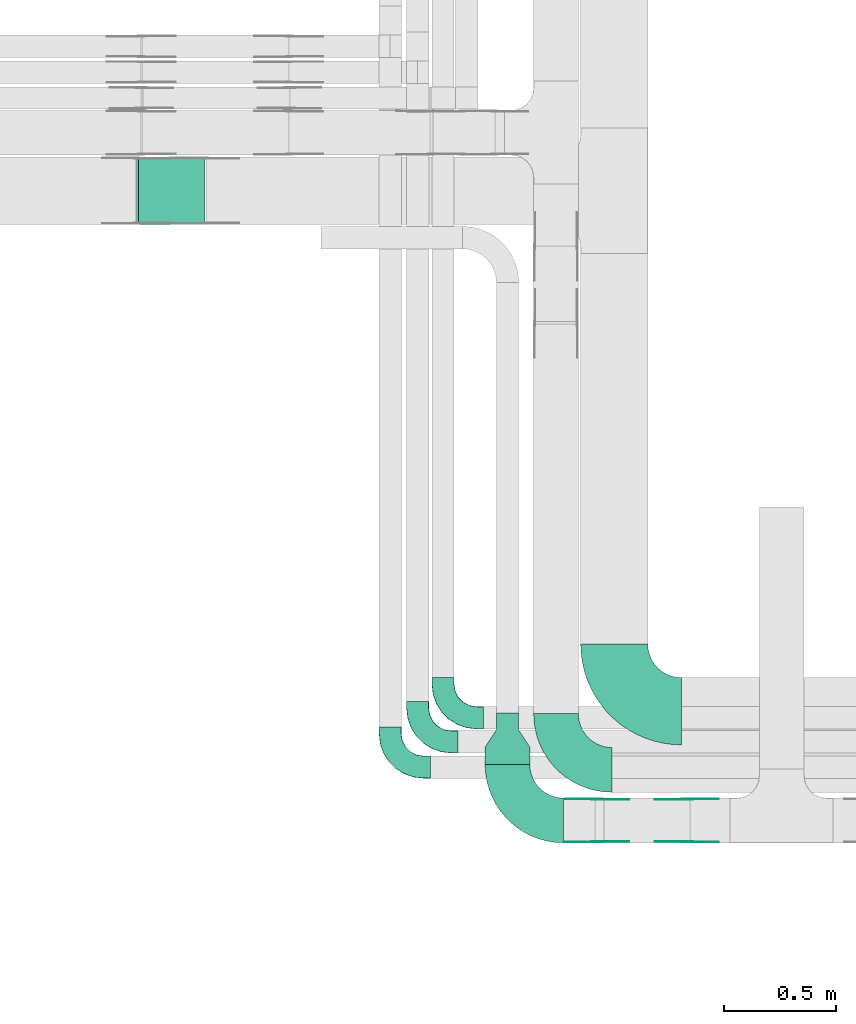
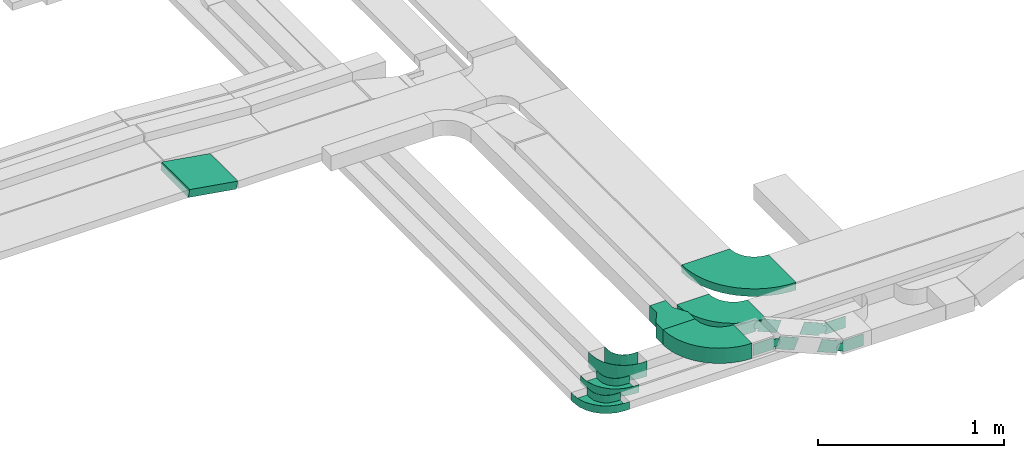
# One storey, part 3 of 19: 15 flow fittings, 1 flow segment.
"""IFC2X3 building model written with IfcOpenShell, lengths in millimetres."""

from ifc_helpers import new_model, entity, si_unit, converted_unit, derived_unit, direction, frame, frame_2d, origin, origin_2d_with_axis, place, context, subcontext, project, spatial, polyline, circle_curve, parameter, trimmed, segment, composite_curve, rectangle, outline, extrude, faceted_brep, source, transform, mapped, material, type_object, type_shapes, element, save


model = new_model("IFC2X3")

# Units and contexts
model_context = context("Model", 3, precision=0.01, world=origin(), true_north=direction((6.12303176911189e-17, 1.0)))
body_context = subcontext(model_context, "Body", "Model", "MODEL_VIEW")
ifc_project = project(units=[si_unit("LENGTHUNIT", "METRE", prefix="MILLI"), si_unit("AREAUNIT", "SQUARE_METRE"), si_unit("VOLUMEUNIT", "CUBIC_METRE"), converted_unit("PLANEANGLEUNIT", "DEGREE", entity("IfcRatioMeasure", 0.0174532925199433), si_unit("PLANEANGLEUNIT", "RADIAN"), dimensions=[0, 0, 0, 0, 0, 0, 0]), si_unit("MASSUNIT", "GRAM", prefix="KILO"), derived_unit("MASSDENSITYUNIT", [(si_unit("MASSUNIT", "GRAM", prefix="KILO"), 1), (si_unit("LENGTHUNIT", "METRE"), -3)]), derived_unit("MOMENTOFINERTIAUNIT", [(si_unit("LENGTHUNIT", "METRE"), 4)]), si_unit("TIMEUNIT", "SECOND"), si_unit("FREQUENCYUNIT", "HERTZ"), si_unit("THERMODYNAMICTEMPERATUREUNIT", "DEGREE_CELSIUS"), derived_unit("THERMALTRANSMITTANCEUNIT", [(si_unit("MASSUNIT", "GRAM", prefix="KILO"), 1), (si_unit("THERMODYNAMICTEMPERATUREUNIT", "KELVIN"), -1), (si_unit("TIMEUNIT", "SECOND"), -3)]), derived_unit("VOLUMETRICFLOWRATEUNIT", [(si_unit("LENGTHUNIT", "METRE"), 3), (si_unit("TIMEUNIT", "SECOND"), -1)]), derived_unit("MASSFLOWRATEUNIT", [(si_unit("MASSUNIT", "GRAM", prefix="KILO"), 1), (si_unit("TIMEUNIT", "SECOND"), -1)]), derived_unit("ROTATIONALFREQUENCYUNIT", [(si_unit("TIMEUNIT", "SECOND"), -1)]), si_unit("ELECTRICCURRENTUNIT", "AMPERE"), si_unit("ELECTRICVOLTAGEUNIT", "VOLT"), si_unit("POWERUNIT", "WATT"), si_unit("FORCEUNIT", "NEWTON", prefix="KILO"), si_unit("ILLUMINANCEUNIT", "LUX"), si_unit("LUMINOUSFLUXUNIT", "LUMEN"), si_unit("LUMINOUSINTENSITYUNIT", "CANDELA"), derived_unit("USERDEFINED", [(si_unit("MASSUNIT", "GRAM", prefix="KILO"), -1), (si_unit("LENGTHUNIT", "METRE"), -2), (si_unit("TIMEUNIT", "SECOND"), 3), (si_unit("LUMINOUSFLUXUNIT", "LUMEN"), 1)]), derived_unit("LINEARVELOCITYUNIT", [(si_unit("LENGTHUNIT", "METRE"), 1), (si_unit("TIMEUNIT", "SECOND"), -1)]), si_unit("PRESSUREUNIT", "PASCAL"), derived_unit("USERDEFINED", [(si_unit("LENGTHUNIT", "METRE"), -2), (si_unit("MASSUNIT", "GRAM", prefix="KILO"), 1), (si_unit("TIMEUNIT", "SECOND"), -2)]), derived_unit("LINEARFORCEUNIT", [(si_unit("MASSUNIT", "GRAM", prefix="KILO"), 1), (si_unit("LENGTHUNIT", "METRE"), 1), (si_unit("TIMEUNIT", "SECOND"), -2), (si_unit("LENGTHUNIT", "METRE"), -1)]), derived_unit("PLANARFORCEUNIT", [(si_unit("MASSUNIT", "GRAM", prefix="KILO"), 1), (si_unit("LENGTHUNIT", "METRE"), 1), (si_unit("TIMEUNIT", "SECOND"), -2), (si_unit("LENGTHUNIT", "METRE"), -2)])], contexts=[model_context])

# Site, building, storey
site_placement = place(None, frame((0.0, -0.00077364408347762, 0.0)))
site = spatial("IfcSite", under=ifc_project, at=site_placement, CompositionType="ELEMENT")
building_placement = place(site_placement, origin())
building = spatial("IfcBuilding", under=site, at=building_placement, CompositionType="ELEMENT")
storey_placement = place(building_placement, frame((0.0, 0.0, 12000.0)))
storey = spatial("IfcBuildingStorey", under=building, at=storey_placement, CompositionType="ELEMENT", Elevation=12000.0)

# Flow segment
cable_carrier_segment_type = type_object("IfcCableCarrierSegmentType", PredefinedType="CABLETRAYSEGMENT")
flow_segment_placement = place(storey_placement, frame((16244.9623547162, 12249.7910307987, 2800.87178897478)))
element("IfcFlowSegment", 1, at=flow_segment_placement, inside=storey, type_object=cable_carrier_segment_type, context=body_context, shape_type="SweptSolid", body=[
    extrude(rectangle(XDim=50.0000000000021, YDim=300.000000000001, at=origin_2d_with_axis()), frame((4.04109573358495, 150.0, 73.5851929511431), z_axis=(0.986849163973504, 0.0, -0.161643829343391), x_axis=(0.161643829343391, 0.0, 0.986849163973504)), (0.0, 0.0, 1.0), 302.603347436749),
])

# Flow fittings
ifc_material_1 = material()
cable_carrier_fitting_type_1 = type_object("IfcCableCarrierFittingType", Name="470_DKC_S5_Variable Angle Elbow 0-45:-", PredefinedType="NOTDEFINED", material=ifc_material_1)
shared_shape_1 = source(origin(), body_context, "Body", "SweptSolid", [
    extrude(outline(composite_curve([segment(polyline([(-150.749999999996, -300.250000000003), (-149.749999999994, -300.250000000003)]), True, "CONTINUOUS"), segment(trimmed(circle_curve(frame_2d((-149.750000000002, 149.749999999997), x_axis=(0.0, -1.0)), 450.0), [parameter(0.0)], [parameter(90.0000000000001)], True, "PARAMETER"), True, "CONTINUOUS"), segment(polyline([(300.249999999997, 149.750000000005), (300.249999999997, 150.750000000004)]), True, "CONTINUOUS"), segment(polyline([(300.249999999997, 150.750000000003), (0.249999999997449, 150.750000000002)]), True, "CONTINUOUS"), segment(polyline([(0.249999999997449, 150.750000000002), (0.249999999997438, 149.75)]), True, "CONTINUOUS"), segment(trimmed(circle_curve(frame_2d((-149.750000000002, 149.749999999997), x_axis=(0.0, -1.0)), 150.0), [parameter(0.0)], [parameter(90.0000000000001)], True, "PARAMETER"), False, "CONTINUOUS"), segment(polyline([(-149.749999999999, -0.250000000002818), (-150.750000000001, -0.250000000002835)]), True, "CONTINUOUS"), segment(polyline([(-150.750000000001, -0.250000000002835), (-150.749999999996, -300.250000000003)]), True, "CONTINUOUS")], self_intersect=False)), frame((-150.249999999991, 150.249999999992, -25.0)), (0.0, 0.0, 1.0), 49.9999999999974),
])
type_shapes(cable_carrier_fitting_type_1, [shared_shape_1])
flow_fitting_1_placement = place(storey_placement, frame((18378.5368087494, 10074.9424515466, 2825.0), z_axis=(0.0, 0.0, 1.0), x_axis=(0.0, -1.0, 0.0)))
element("IfcFlowFitting", 2, at=flow_fitting_1_placement, inside=storey, type_object=cable_carrier_fitting_type_1, material=ifc_material_1, Name="470_DKC_S5_Variable Angle Elbow 0-45:-", ObjectType="470_DKC_S5_Variable Angle Elbow 0-45:-", context=body_context, shape_type="MappedRepresentation", body=[
    mapped(shared_shape_1, transform((0.0, 0.0, 0.0), scale=1.0)),
])
cable_carrier_fitting_type_2 = type_object("IfcCableCarrierFittingType", Name="470_DKC_S5_Variable Angle Elbow 0-45:-", PredefinedType="NOTDEFINED", material=ifc_material_1)
shared_shape_2 = source(origin(), body_context, "Body", "SweptSolid", [
    extrude(outline(composite_curve([segment(polyline([(-125.750000000004, -225.249999999998), (-124.750000000003, -225.249999999998)]), True, "CONTINUOUS"), segment(trimmed(circle_curve(frame_2d((-124.749999999998, 124.750000000002), x_axis=(0.0, -1.0)), 350.0), [parameter(0.0)], [parameter(90.0000000000001)], True, "PARAMETER"), True, "CONTINUOUS"), segment(polyline([(225.250000000002, 124.749999999996), (225.250000000002, 125.749999999995)]), True, "CONTINUOUS"), segment(polyline([(225.250000000002, 125.749999999995), (25.2500000000021, 125.750000000001)]), True, "CONTINUOUS"), segment(polyline([(25.2500000000021, 125.750000000001), (25.2500000000021, 124.749999999999)]), True, "CONTINUOUS"), segment(trimmed(circle_curve(frame_2d((-124.749999999998, 124.750000000002), x_axis=(0.0, -1.0)), 150.0), [parameter(0.0)], [parameter(90.0000000000001)], True, "PARAMETER"), False, "CONTINUOUS"), segment(polyline([(-124.75, -25.2499999999982), (-125.750000000001, -25.2499999999981)]), True, "CONTINUOUS"), segment(polyline([(-125.750000000001, -25.2499999999981), (-125.750000000004, -225.249999999998)]), True, "CONTINUOUS")], self_intersect=False)), frame((-125.249999999991, 125.249999999992, -25.0)), (0.0, 0.0, 1.0), 50.000000000001),
])
type_shapes(cable_carrier_fitting_type_2, [shared_shape_2])
flow_fitting_2_placement = place(storey_placement, frame((18118.5874268759, 9813.17561885424, 2825.80524984479), z_axis=(0.0, 0.0, 1.0), x_axis=(0.0, -1.0, 0.0)))
element("IfcFlowFitting", 3, at=flow_fitting_2_placement, inside=storey, type_object=cable_carrier_fitting_type_2, material=ifc_material_1, Name="470_DKC_S5_Variable Angle Elbow 0-45:-", ObjectType="470_DKC_S5_Variable Angle Elbow 0-45:-", context=body_context, shape_type="MappedRepresentation", body=[
    mapped(shared_shape_2, transform((0.0, 0.0, 0.0), scale=1.0)),
])
ifc_material_2 = material(Name="G")
cable_carrier_fitting_type_3 = type_object("IfcCableCarrierFittingType", PredefinedType="NOTDEFINED", material=ifc_material_2)
shared_shape_3 = source(origin(), body_context, "Body", "SweptSolid", [
    extrude(outline(composite_curve([segment(trimmed(circle_curve(frame_2d((-41.4651162790697, 0.0), x_axis=(1.0, 0.0)), 25.0), [parameter(90.0000000000007)], [parameter(270.0)], True, "PARAMETER"), True, "CONTINUOUS"), segment(polyline([(-41.4651162790697, -25.0), (-29.9651162790697, -25.0)]), True, "CONTINUOUS"), segment(polyline([(-29.9651162790697, -25.0), (-28.1046511627907, -38.5)]), True, "CONTINUOUS"), segment(polyline([(-28.1046511627907, -38.5), (99.5348837209303, -38.5)]), True, "CONTINUOUS"), segment(polyline([(99.5348837209303, -38.5), (99.5348837209303, 38.5)]), True, "CONTINUOUS"), segment(polyline([(99.5348837209303, 38.5), (-28.1046511627907, 38.5)]), True, "CONTINUOUS"), segment(polyline([(-28.1046511627907, 38.5), (-29.9651162790697, 25.0)]), True, "CONTINUOUS"), segment(polyline([(-29.9651162790697, 25.0), (-41.46511627907, 25.0)]), True, "CONTINUOUS")], self_intersect=False)), frame((41.4651162790697, 0.0, 0.0), z_axis=(0.0, 0.0, -1.0), x_axis=(1.0, 0.0, 0.0)), (0.0, 0.0, -1.0), 2.0),
])
type_shapes(cable_carrier_fitting_type_3, [shared_shape_3])
for number, where, z_axis, x_axis in (
    (4, (18301.6734101346, 9491.98715306406, 2850.0), (0.0, -1.0, 0.0), (-1.0, 0.0, 0.0)),
    (5, (18705.34797877, 9491.98715306406, 2678.65031167224), (0.0, -1.0, 0.0), (1.0, 0.0, 0.0)),
):
    element("IfcFlowFitting", number, at=place(storey_placement, frame(where, z_axis=z_axis, x_axis=x_axis)), inside=storey, type_object=cable_carrier_fitting_type_3, material=ifc_material_2, context=body_context, shape_type="MappedRepresentation", body=[
        mapped(shared_shape_3, transform((0.0, 0.0, 0.0), scale=1.0)),
    ])
cable_carrier_fitting_type_4 = type_object("IfcCableCarrierFittingType", PredefinedType="NOTDEFINED", material=ifc_material_2)
shared_shape_4 = source(origin(), body_context, "Body", "SweptSolid", [
    extrude(outline(composite_curve([segment(trimmed(circle_curve(frame_2d((-41.4651162790697, 0.0), x_axis=(1.0, 0.0)), 25.0), [parameter(90.0000000000007)], [parameter(270.0)], True, "PARAMETER"), True, "CONTINUOUS"), segment(polyline([(-41.4651162790697, -25.0), (-29.9651162790697, -25.0)]), True, "CONTINUOUS"), segment(polyline([(-29.9651162790697, -25.0), (-28.1046511627907, -38.5)]), True, "CONTINUOUS"), segment(polyline([(-28.1046511627907, -38.5), (99.5348837209303, -38.5)]), True, "CONTINUOUS"), segment(polyline([(99.5348837209303, -38.5), (99.5348837209303, 38.5)]), True, "CONTINUOUS"), segment(polyline([(99.5348837209303, 38.5), (-28.1046511627907, 38.5)]), True, "CONTINUOUS"), segment(polyline([(-28.1046511627907, 38.5), (-29.9651162790697, 25.0)]), True, "CONTINUOUS"), segment(polyline([(-29.9651162790697, 25.0), (-41.46511627907, 25.0)]), True, "CONTINUOUS")], self_intersect=False)), frame((41.4651162790697, 0.0, 0.0)), (0.0, 0.0, 1.0), 2.0),
])
type_shapes(cable_carrier_fitting_type_4, [shared_shape_4])
for number, where, z_axis, x_axis in (
    (6, (18301.6734101346, 9682.90715308437, 2850.0), (0.0, 1.0, 0.0), (-1.0, 0.0, 0.0)),
    (7, (18705.34797877, 9682.90715308437, 2678.65031167224), (0.0, 1.0, 0.0), (1.0, 0.0, 0.0)),
):
    element("IfcFlowFitting", number, at=place(storey_placement, frame(where, z_axis=z_axis, x_axis=x_axis)), inside=storey, type_object=cable_carrier_fitting_type_4, material=ifc_material_2, context=body_context, shape_type="MappedRepresentation", body=[
        mapped(shared_shape_4, transform((0.0, 0.0, 0.0), scale=1.0)),
    ])
cable_carrier_fitting_type_5 = type_object("IfcCableCarrierFittingType", PredefinedType="NOTDEFINED", material=ifc_material_2)
shared_shape_5 = source(origin(), body_context, "Body", "SweptSolid", [
    extrude(outline(composite_curve([segment(trimmed(circle_curve(frame_2d((-41.4651162790697, 0.0), x_axis=(1.0, 0.0)), 25.0), [parameter(90.0000000000007)], [parameter(270.0)], True, "PARAMETER"), True, "CONTINUOUS"), segment(polyline([(-41.4651162790697, -25.0), (-29.9651162790697, -25.0)]), True, "CONTINUOUS"), segment(polyline([(-29.9651162790697, -25.0), (-28.1046511627907, -38.5)]), True, "CONTINUOUS"), segment(polyline([(-28.1046511627907, -38.5), (99.5348837209303, -38.5)]), True, "CONTINUOUS"), segment(polyline([(99.5348837209303, -38.5), (99.5348837209303, 38.5)]), True, "CONTINUOUS"), segment(polyline([(99.5348837209303, 38.5), (-28.1046511627907, 38.5)]), True, "CONTINUOUS"), segment(polyline([(-28.1046511627907, 38.5), (-29.9651162790697, 25.0)]), True, "CONTINUOUS"), segment(polyline([(-29.9651162790697, 25.0), (-41.46511627907, 25.0)]), True, "CONTINUOUS")], self_intersect=False)), frame((41.4651162790697, 0.0, 0.0), z_axis=(0.0, 0.0, -1.0), x_axis=(1.0, 0.0, 0.0)), (0.0, 0.0, -1.0), 2.0),
])
type_shapes(cable_carrier_fitting_type_5, [shared_shape_5])
for number, where, z_axis, x_axis in (
    (8, (18301.6734101346, 9680.90715308437, 2850.0), (0.0, 1.0, 0.0), (0.920504853452409, 0.0, -0.390731128489347)),
    (9, (18705.3479787701, 9680.90715308437, 2678.65031167224), (0.0, 1.0, 0.0), (-0.920504853454354, 0.0, 0.390731128484765)),
):
    element("IfcFlowFitting", number, at=place(storey_placement, frame(where, z_axis=z_axis, x_axis=x_axis)), inside=storey, type_object=cable_carrier_fitting_type_5, material=ifc_material_2, context=body_context, shape_type="MappedRepresentation", body=[
        mapped(shared_shape_5, transform((0.0, 0.0, 0.0), scale=1.0)),
    ])
cable_carrier_fitting_type_6 = type_object("IfcCableCarrierFittingType", PredefinedType="NOTDEFINED", material=ifc_material_2)
shared_shape_6 = source(origin(), body_context, "Body", "SweptSolid", [
    extrude(outline(composite_curve([segment(trimmed(circle_curve(frame_2d((-41.4651162790697, 0.0), x_axis=(1.0, 0.0)), 25.0), [parameter(90.0000000000007)], [parameter(270.0)], True, "PARAMETER"), True, "CONTINUOUS"), segment(polyline([(-41.4651162790697, -25.0), (-29.9651162790697, -25.0)]), True, "CONTINUOUS"), segment(polyline([(-29.9651162790697, -25.0), (-28.1046511627907, -38.5)]), True, "CONTINUOUS"), segment(polyline([(-28.1046511627907, -38.5), (99.5348837209303, -38.5)]), True, "CONTINUOUS"), segment(polyline([(99.5348837209303, -38.5), (99.5348837209303, 38.5)]), True, "CONTINUOUS"), segment(polyline([(99.5348837209303, 38.5), (-28.1046511627907, 38.5)]), True, "CONTINUOUS"), segment(polyline([(-28.1046511627907, 38.5), (-29.9651162790697, 25.0)]), True, "CONTINUOUS"), segment(polyline([(-29.9651162790697, 25.0), (-41.46511627907, 25.0)]), True, "CONTINUOUS")], self_intersect=False)), frame((41.4651162790697, 0.0, 0.0)), (0.0, 0.0, 1.0), 2.0),
])
type_shapes(cable_carrier_fitting_type_6, [shared_shape_6])
for number, where, z_axis, x_axis in (
    (10, (18301.6734101346, 9493.98715306406, 2850.0), (0.0, -1.0, 0.0), (0.920504853452409, 0.0, -0.390731128489347)),
    (11, (18705.3479787701, 9493.98715306406, 2678.65031167224), (0.0, -1.0, 0.0), (-0.920504853454354, 0.0, 0.390731128484765)),
):
    element("IfcFlowFitting", number, at=place(storey_placement, frame(where, z_axis=z_axis, x_axis=x_axis)), inside=storey, type_object=cable_carrier_fitting_type_6, material=ifc_material_2, context=body_context, shape_type="MappedRepresentation", body=[
        mapped(shared_shape_6, transform((0.0, 0.0, 0.0), scale=1.0)),
    ])
cable_carrier_fitting_type_7 = type_object("IfcCableCarrierFittingType", Name="470_DKC_S5_Variable Angle Elbow 0-45:-", PredefinedType="NOTDEFINED", material=ifc_material_1)
shared_shape_7 = source(origin(), body_context, "Body", "SweptSolid", [
    extrude(outline(composite_curve([segment(polyline([(-125.750000000001, -225.25), (-124.749999999999, -225.25)]), True, "CONTINUOUS"), segment(trimmed(circle_curve(frame_2d((-124.75, 124.75), x_axis=(0.0, -1.0)), 350.0), [parameter(0.0)], [parameter(90.0000000000001)], True, "PARAMETER"), True, "CONTINUOUS"), segment(polyline([(225.25, 124.75), (225.25, 125.749999999999)]), True, "CONTINUOUS"), segment(polyline([(225.25, 125.749999999999), (25.25, 125.750000000001)]), True, "CONTINUOUS"), segment(polyline([(25.25, 125.750000000001), (25.25, 124.75)]), True, "CONTINUOUS"), segment(trimmed(circle_curve(frame_2d((-124.75, 124.75), x_axis=(0.0, -1.0)), 150.0), [parameter(0.0)], [parameter(90.0000000000001)], True, "PARAMETER"), False, "CONTINUOUS"), segment(polyline([(-124.749999999999, -25.2500000000003), (-125.750000000001, -25.2500000000003)]), True, "CONTINUOUS"), segment(polyline([(-125.750000000001, -25.2500000000003), (-125.750000000001, -225.25)]), True, "CONTINUOUS")], self_intersect=False)), frame((-125.249999999991, 125.249999999992, -50.0)), (0.0, 0.0, 1.0), 100.0),
])
type_shapes(cable_carrier_fitting_type_7, [shared_shape_7])
flow_fitting_3_placement = place(storey_placement, frame((17901.6734101346, 9587.44715307423, 2850.0), z_axis=(0.0, 0.0, 1.0), x_axis=(0.0, -1.0, 0.0)))
element("IfcFlowFitting", 12, at=flow_fitting_3_placement, inside=storey, type_object=cable_carrier_fitting_type_7, material=ifc_material_1, Name="470_DKC_S5_Variable Angle Elbow 0-45:-", ObjectType="470_DKC_S5_Variable Angle Elbow 0-45:-", context=body_context, shape_type="MappedRepresentation", body=[
    mapped(shared_shape_7, transform((0.0, 0.0, 0.0), scale=1.0)),
])
cable_carrier_fitting_type_8 = type_object("IfcCableCarrierFittingType", PredefinedType="NOTDEFINED", material=ifc_material_1)
shared_shape_8 = source(origin(), body_context, "Body", "SweptSolid", [
    extrude(outline(polyline([(-115.0, -100.0), (-38.3333333333284, -100.0), (38.3333333333252, -50.0), (115.0, -50.0), (115.0, 50.0), (38.3333333333382, 50.0), (-38.3333333333284, 100.0), (-115.0, 100.0), (-115.0, -100.0)])), frame((115.0, 0.0, -50.0)), (0.0, 0.0, 1.0), 100.0),
])
type_shapes(cable_carrier_fitting_type_8, [shared_shape_8])
flow_fitting_4_placement = place(storey_placement, frame((17901.6734101346, 9838.44715307421, 2850.0), z_axis=(0.0, 0.0, 1.0), x_axis=(0.0, 1.0, 0.0)))
element("IfcFlowFitting", 13, at=flow_fitting_4_placement, inside=storey, type_object=cable_carrier_fitting_type_8, material=ifc_material_1, Name="470_DKC_S5_adapter", context=body_context, shape_type="MappedRepresentation", body=[
    mapped(shared_shape_8, transform((0.0, 0.0, 0.0), scale=1.0)),
])
cable_carrier_fitting_type_9 = type_object("IfcCableCarrierFittingType", Name="470_DKC_S5_CPO 45 horizontal angle:-", PredefinedType="NOTDEFINED", material=ifc_material_1)
shared_shape_9 = source(origin(), body_context, "Body", "Brep", [
    faceted_brep([(-180.0, -49.2000000000082, -49.2000000000019), (-180.0, 49.1999999999917, -49.2000000000019), (-180.0, 49.1999999999917, 50.0), (-180.0, 50.0, 50.0), (-180.0, 50.0, -50.0), (-180.0, -50.0, -50.0), (-180.0, -50.0, 50.0), (-180.0, -49.2000000000082, 50.0), (-150.0, -50.0, -50.0), (-150.0, -50.0, 50.0), (-105.495813208728, -44.9855824363732, 50.0), (-63.2232521764796, -30.1937735804923, 50.0), (-25.3020396282445, -6.36629649361443, 50.0), (6.3662964936147, 25.3020396282448, 50.0), (30.1937735804926, 63.2232521764798, 50.0), (44.9855824363735, 105.495813208729, 50.0), (50.0, 150.0, 50.0), (50.0, 180.0, 50.0), (49.2000000000087, 180.0, 50.0), (49.2000000000086, 150.0, 50.0), (44.2056401066279, 105.673829955894, 50.0), (29.4729984861705, 63.5703591677739, 50.0), (5.74083130764015, 25.8008314697319, 50.0), (-25.8008314697316, -5.74083130763988, 50.0), (-63.5703591677737, -29.4729984861702, 50.0), (-105.673829955893, -44.2056401066275, 50.0), (-150.0, -49.2000000000082, 50.0), (-150.0, 49.1999999999917, 50.0), (-118.851086966997, 54.1335031574402, 50.0), (-90.75124656891, 68.451086966997, 50.0), (-68.4510869669966, 90.7512465689103, 50.0), (-54.1335031574399, 118.851086966997, 50.0), (-49.1999999999913, 150.0, 50.0), (-49.1999999999912, 180.0, 50.0), (-50.0, 180.0, 50.0), (-50.0, 150.0, 50.0), (-54.8943483704758, 119.098300562497, 50.0), (-69.0983005624964, 91.2214747707442, 50.0), (-91.2214747707439, 69.0983005624968, 50.0), (-119.098300562496, 54.8943483704762, 50.0), (-150.0, 50.0, 50.0), (-150.0, -49.2000000000082, -49.2000000000019), (-105.673829955893, -44.2056401066275, -49.2000000000019), (-63.5703591677737, -29.4729984861702, -49.2000000000019), (-25.8008314697316, -5.74083130763988, -49.2000000000019), (5.74083130764015, 25.8008314697319, -49.2000000000019), (29.4729984861705, 63.5703591677739, -49.2000000000019), (44.2056401066279, 105.673829955894, -49.2000000000019), (49.2000000000087, 150.0, -49.2000000000019), (49.2000000000087, 180.0, -49.2000000000019), (-49.1999999999912, 180.0, -49.2000000000019), (-49.1999999999913, 150.0, -49.2000000000019), (-54.1335031574399, 118.851086966997, -49.2000000000019), (-68.4510869669966, 90.7512465689103, -49.2000000000019), (-90.75124656891, 68.451086966997, -49.2000000000019), (-118.851086966997, 54.1335031574402, -49.2000000000019), (-150.0, 49.1999999999917, -49.2000000000019), (-150.0, 50.0, -50.0), (-119.098300562496, 54.8943483704762, -50.0), (-91.2214747707439, 69.0983005624968, -50.0), (-69.0983005624964, 91.2214747707442, -50.0), (-54.8943483704758, 119.098300562497, -50.0), (-50.0, 150.0, -50.0), (-50.0, 180.0, -50.0), (50.0, 180.0, -50.0), (50.0, 150.0, -50.0), (44.9855824363735, 105.495813208729, -50.0), (30.1937735804926, 63.2232521764798, -50.0), (6.3662964936147, 25.3020396282448, -50.0), (-25.3020396282445, -6.36629649361443, -50.0), (-63.2232521764796, -30.1937735804923, -50.0), (-105.495813208728, -44.9855824363732, -50.0)], [[[0, 1, 2, 3, 4, 5, 6, 7]], [[6, 5, 8, 9]], [[7, 6, 9, 10, 11, 12, 13, 14, 15, 16, 17, 18, 19, 20, 21, 22, 23, 24, 25, 26]], [[3, 2, 27, 28, 29, 30, 31, 32, 33, 34, 35, 36, 37, 38, 39, 40]], [[0, 7, 26, 41]], [[1, 0, 41, 42, 43, 44, 45, 46, 47, 48, 49, 50, 51, 52, 53, 54, 55, 56]], [[2, 1, 56, 27]], [[4, 3, 40, 57]], [[57, 58, 59, 60, 61, 62, 63, 64, 65, 66, 67, 68, 69, 70, 71, 8, 5, 4]], [[10, 9, 8, 71]], [[71, 70, 11, 10]], [[69, 12, 11, 70]], [[69, 68, 13, 12]], [[13, 68, 67, 14]], [[14, 67, 66, 15]], [[15, 66, 65, 16]], [[42, 41, 26, 25]], [[24, 43, 42, 25]], [[43, 24, 23, 44]], [[23, 22, 45, 44]], [[46, 45, 22, 21]], [[47, 46, 21, 20]], [[48, 47, 20, 19]], [[55, 54, 29, 28]], [[56, 55, 28, 27]], [[54, 53, 30, 29]], [[30, 53, 52, 31]], [[31, 52, 51, 32]], [[39, 38, 59, 58]], [[39, 58, 57, 40]], [[38, 37, 60, 59]], [[61, 60, 37, 36]], [[62, 61, 36, 35]], [[63, 34, 33, 50, 49, 18, 17, 64]], [[16, 65, 64, 17]], [[48, 19, 18, 49]], [[32, 51, 50, 33]], [[62, 35, 34, 63]]]),
])
type_shapes(cable_carrier_fitting_type_9, [shared_shape_9])
flow_fitting_5_placement = place(storey_placement, frame((17613.8576157091, 10046.0027315095, 2550.0), z_axis=(0.0, -0.000495218494767808, 0.999999877379314), x_axis=(0.0, -0.999999877379314, -0.000495218494767808)))
element("IfcFlowFitting", 14, at=flow_fitting_5_placement, inside=storey, type_object=cable_carrier_fitting_type_9, material=ifc_material_1, Name="470_DKC_S5_45 horizontal angle", ObjectType="470_DKC_S5_CPO 45 horizontal angle:-", context=body_context, shape_type="MappedRepresentation", body=[
    mapped(shared_shape_9, transform((0.0, 0.0, 0.0), scale=1.0)),
])
cable_carrier_fitting_type_10 = type_object("IfcCableCarrierFittingType", Name="470_DKC_S5_CPO 45 horizontal angle:-", PredefinedType="NOTDEFINED", material=ifc_material_1)
shared_shape_10 = source(origin(), body_context, "Body", "Brep", [
    faceted_brep([(-180.0, -49.2000000000082, -24.2000000000019), (-180.0, 49.1999999999917, -24.2000000000019), (-180.0, 49.1999999999917, 25.0), (-180.0, 50.0, 25.0), (-180.0, 50.0, -25.0), (-180.0, -50.0, -25.0), (-180.0, -50.0, 25.0), (-180.0, -49.2000000000082, 25.0), (-150.0, -50.0, -25.0), (-150.0, -50.0, 25.0), (-105.495813208728, -44.9855824363732, 25.0), (-63.2232521764796, -30.1937735804923, 25.0), (-25.3020396282445, -6.36629649361443, 25.0), (6.3662964936147, 25.3020396282448, 25.0), (30.1937735804926, 63.2232521764798, 25.0), (44.9855824363735, 105.495813208729, 25.0), (50.0, 150.0, 25.0), (50.0, 180.0, 25.0), (49.2000000000087, 180.0, 25.0), (49.2000000000086, 150.0, 25.0), (44.2056401066279, 105.673829955894, 25.0), (29.4729984861705, 63.5703591677739, 25.0), (5.74083130764015, 25.8008314697319, 25.0), (-25.8008314697316, -5.74083130763988, 25.0), (-63.5703591677737, -29.4729984861702, 25.0), (-105.673829955893, -44.2056401066275, 25.0), (-150.0, -49.2000000000082, 25.0), (-150.0, 49.1999999999917, 25.0), (-118.851086966997, 54.1335031574402, 25.0), (-90.75124656891, 68.451086966997, 25.0), (-68.4510869669966, 90.7512465689103, 25.0), (-54.1335031574399, 118.851086966997, 25.0), (-49.1999999999913, 150.0, 25.0), (-49.1999999999912, 180.0, 25.0), (-50.0, 180.0, 25.0), (-50.0, 150.0, 25.0), (-54.8943483704758, 119.098300562497, 25.0), (-69.0983005624964, 91.2214747707442, 25.0), (-91.2214747707439, 69.0983005624968, 25.0), (-119.098300562496, 54.8943483704762, 25.0), (-150.0, 50.0, 25.0), (-150.0, -49.2000000000082, -24.2000000000019), (-105.673829955893, -44.2056401066275, -24.2000000000019), (-63.5703591677737, -29.4729984861702, -24.2000000000019), (-25.8008314697316, -5.74083130763988, -24.2000000000019), (5.74083130764015, 25.8008314697319, -24.2000000000019), (29.4729984861705, 63.5703591677739, -24.2000000000019), (44.2056401066279, 105.673829955894, -24.2000000000019), (49.2000000000087, 150.0, -24.2000000000019), (49.2000000000087, 180.0, -24.2000000000019), (-49.1999999999913, 180.0, -24.2000000000019), (-49.1999999999913, 150.0, -24.2000000000019), (-54.1335031574399, 118.851086966997, -24.2000000000019), (-68.4510869669966, 90.7512465689103, -24.2000000000019), (-90.75124656891, 68.451086966997, -24.2000000000019), (-118.851086966997, 54.1335031574402, -24.2000000000019), (-150.0, 49.1999999999917, -24.2000000000019), (-150.0, 50.0, -25.0), (-119.098300562496, 54.8943483704762, -25.0), (-91.2214747707439, 69.0983005624968, -25.0), (-69.0983005624964, 91.2214747707442, -25.0), (-54.8943483704758, 119.098300562497, -25.0), (-50.0, 150.0, -25.0), (-50.0, 180.0, -25.0), (50.0, 180.0, -25.0), (50.0, 150.0, -25.0), (44.9855824363735, 105.495813208729, -25.0), (30.1937735804926, 63.2232521764798, -25.0), (6.3662964936147, 25.3020396282448, -25.0), (-25.3020396282445, -6.36629649361443, -25.0), (-63.2232521764796, -30.1937735804923, -25.0), (-105.495813208728, -44.9855824363732, -25.0)], [[[0, 1, 2, 3, 4, 5, 6, 7]], [[6, 5, 8, 9]], [[7, 6, 9, 10, 11, 12, 13, 14, 15, 16, 17, 18, 19, 20, 21, 22, 23, 24, 25, 26]], [[3, 2, 27, 28, 29, 30, 31, 32, 33, 34, 35, 36, 37, 38, 39, 40]], [[0, 7, 26, 41]], [[1, 0, 41, 42, 43, 44, 45, 46, 47, 48, 49, 50, 51, 52, 53, 54, 55, 56]], [[2, 1, 56, 27]], [[4, 3, 40, 57]], [[57, 58, 59, 60, 61, 62, 63, 64, 65, 66, 67, 68, 69, 70, 71, 8, 5, 4]], [[10, 9, 8, 71]], [[71, 70, 11, 10]], [[69, 12, 11, 70]], [[69, 68, 13, 12]], [[68, 67, 14, 13]], [[67, 66, 15, 14]], [[15, 66, 65, 16]], [[42, 41, 26, 25]], [[24, 43, 42, 25]], [[43, 24, 23, 44]], [[23, 22, 45, 44]], [[21, 46, 45, 22]], [[21, 20, 47, 46]], [[48, 47, 20, 19]], [[28, 27, 56, 55]], [[29, 28, 55, 54]], [[54, 53, 30, 29]], [[31, 30, 53, 52]], [[31, 52, 51, 32]], [[58, 57, 40, 39]], [[59, 58, 39, 38]], [[38, 37, 60, 59]], [[61, 60, 37, 36]], [[62, 61, 36, 35]], [[63, 34, 33, 50, 49, 18, 17, 64]], [[16, 65, 64, 17]], [[48, 19, 18, 49]], [[32, 51, 50, 33]], [[62, 35, 34, 63]]]),
])
type_shapes(cable_carrier_fitting_type_10, [shared_shape_10])
for number, where, z_axis, x_axis, name in (
    (15, (17377.7611527256, 9825.5022288233, 2525.0), (0.0, 0.0, 1.0), (0.0, -1.0, 0.0), "470_DKC_S5_45 horizontal angle"),
    (16, (17500.803072578, 9938.36195699675, 2525.0), (0.0, 0.0, 1.0), (0.0, -1.0, 0.0), "470_DKC_S5_45 horizontal angle"),
):
    element("IfcFlowFitting", number, at=place(storey_placement, frame(where, z_axis=z_axis, x_axis=x_axis)), inside=storey, type_object=cable_carrier_fitting_type_10, material=ifc_material_1, Name=name, ObjectType="470_DKC_S5_CPO 45 horizontal angle:-", context=body_context, shape_type="MappedRepresentation", body=[
        mapped(shared_shape_10, transform((0.0, 0.0, 0.0), scale=1.0)),
    ])

save(model, "model.ifc")
